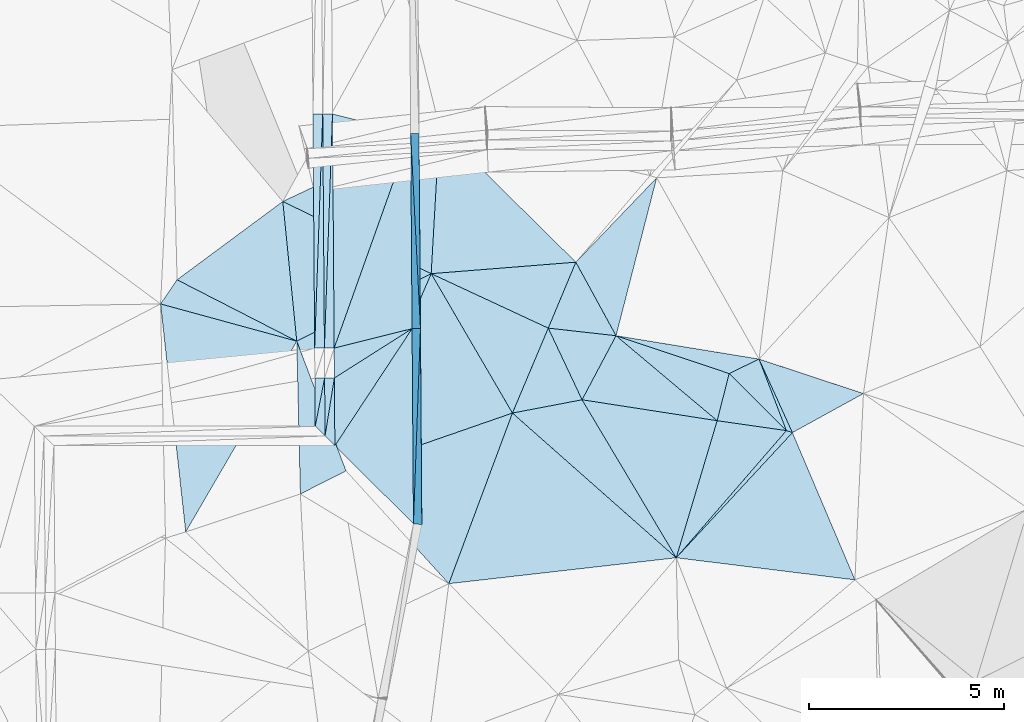
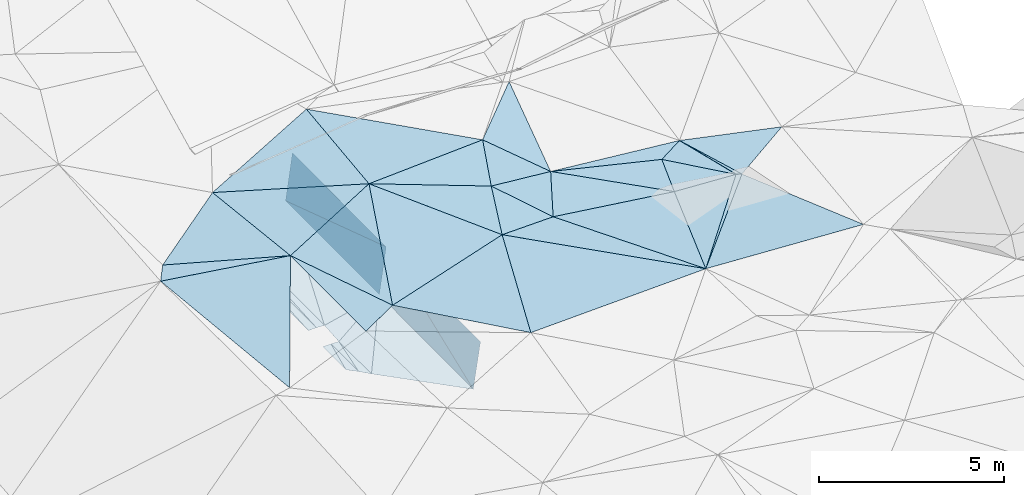
# One storey, part 99 of 275: 46 plates.
"""IFC2X3 building model written with IfcOpenShell, lengths in millimetres."""

from ifc_helpers import new_model, si_unit, frame, origin_with_axes, place, context, subcontext, project, spatial, polyline, outline, extrude, material, type_object, element, save


model = new_model("IFC2X3")

# Units and contexts
model_context = context("Model", 3, precision=1e-05, world=origin_with_axes())
body_context = subcontext(model_context, "Body", "Model", "MODEL_VIEW")
ifc_project = project(units=[si_unit("LENGTHUNIT", "METRE", prefix="MILLI"), si_unit("AREAUNIT", "SQUARE_METRE"), si_unit("VOLUMEUNIT", "CUBIC_METRE"), si_unit("MASSUNIT", "GRAM", prefix="KILO"), si_unit("TIMEUNIT", "SECOND"), si_unit("PLANEANGLEUNIT", "RADIAN"), si_unit("SOLIDANGLEUNIT", "STERADIAN"), si_unit("THERMODYNAMICTEMPERATUREUNIT", "DEGREE_CELSIUS"), si_unit("LUMINOUSINTENSITYUNIT", "LUMEN")], contexts=[model_context])

# Site, building, storey
site_placement = place(None, origin_with_axes())
site = spatial("IfcSite", under=ifc_project, at=site_placement, CompositionType="ELEMENT")
building_placement = place(site_placement, origin_with_axes())
building = spatial("IfcBuilding", under=site, at=building_placement, Name="Undefined", CompositionType="ELEMENT")
storey_placement = place(building_placement, origin_with_axes())
storey = spatial("IfcBuildingStorey", under=building, at=storey_placement, Name="Undefined", CompositionType="ELEMENT", Elevation=0.0)

# Plates
ifc_material = material()
plate_type_1 = type_object("IfcPlateType", PredefinedType="NOTDEFINED")
plate_1_placement = place(storey_placement, frame((-38804.1459852921, 42094.3332256138, 44429.500769745), z_axis=(0.0555257662861849, -0.00520451636578877, -0.998443690093603), x_axis=(0.285934340312549, 0.958187139763384, 0.0109067970593126)))
element("IfcPlate", 1, at=plate_1_placement, inside=storey, type_object=plate_type_1, material=ifc_material, Name="00", context=body_context, shape_type="SweptSolid", body=[
    extrude(outline(polyline([(0.0, 0.0), (3667.43774414063, 6.25732354819775e-10), (3932.2275390625, 1775.60876464844), (0.0, 0.0)])), frame((-8.85201319254618e-08, 2.18876761149539e-07, -0.5000001331573), z_axis=(0.0, 0.0, 1.0), x_axis=(1.0, 0.0, 0.0)), (0.0, 0.0, 1.0), 1.0),
])
plate_type_2 = type_object("IfcPlateType", PredefinedType="NOTDEFINED")
plate_2_placement = place(storey_placement, frame((-45538.5353842683, 42966.5050686624, 42291.0672885135), z_axis=(0.989902123787264, 0.00969248923613964, -0.141420793993923), x_axis=(-0.00717845203227998, 0.999807203879401, 0.0182763480289049)))
element("IfcPlate", 2, at=plate_2_placement, inside=storey, type_object=plate_type_2, material=ifc_material, Name="00_PR", context=body_context, shape_type="SweptSolid", body=[
    extrude(outline(polyline([(0.0, 0.0), (5000.8349609375, 5.12955011799932e-09), (5028.2490234375, 1514.98083496094), (0.0, 0.0)])), frame((-8.85201319254618e-08, 2.18876761149539e-07, -0.5000001331573), z_axis=(0.0, 0.0, 1.0), x_axis=(1.0, 0.0, 0.0)), (0.0, 0.0, 1.0), 1.0),
])
plate_type_3 = type_object("IfcPlateType", PredefinedType="NOTDEFINED")
for number, where, z_axis, x_axis, name in (
    (3, (-45396.0518271226, 52967.7848964947, 43960.1482889428), (0.989905826541836, 0.00930464635209911, -0.14142092537806), (0.00717878401248053, -0.999853554844082, -0.0155349259976933), "00_PR"),
    (4, (-45574.4336350125, 47966.375828221, 42382.4642885271), (0.989905826541836, 0.00930464635209911, -0.14142092537806), (-0.00717878403133616, 0.99985355484347, 0.0155349260283608), "00_PR"),
):
    element("IfcPlate", number, at=place(storey_placement, frame(where, z_axis=z_axis, x_axis=x_axis)), inside=storey, type_object=plate_type_3, material=ifc_material, Name=name, context=body_context, shape_type="SweptSolid", body=[
        extrude(outline(polyline([(0.0, 0.0), (5000.60302734375, -2.69210431724787e-09), (23.3020057678223, 1515.04956054688), (0.0, 0.0)])), frame((-8.85201319254618e-08, 2.18876761149539e-07, -0.5000001331573), z_axis=(0.0, 0.0, 1.0), x_axis=(1.0, 0.0, 0.0)), (0.0, 0.0, 1.0), 1.0),
    ])
plate_type_4 = type_object("IfcPlateType", PredefinedType="NOTDEFINED")
plate_3_placement = place(storey_placement, frame((-45360.1535715881, 47967.9141256778, 43882.4643262462), z_axis=(0.989912967878838, 0.00966846638336566, -0.141346513162173), x_axis=(0.00717851601274934, -0.999810135650778, -0.0181152299965372)))
element("IfcPlate", 5, at=plate_3_placement, inside=storey, type_object=plate_type_4, material=ifc_material, Name="00_PR", context=body_context, shape_type="SweptSolid", body=[
    extrude(outline(polyline([(0.0, 0.0), (5023.06640625, -4.80213202536106e-10), (5028.00732421875, 1515.78295898438), (0.0, 0.0)])), frame((-8.85201319254618e-08, 2.18876761149539e-07, -0.5000001331573), z_axis=(0.0, 0.0, 1.0), x_axis=(1.0, 0.0, 0.0)), (0.0, 0.0, 1.0), 1.0),
])
plate_type_5 = type_object("IfcPlateType", PredefinedType="NOTDEFINED")
plate_4_placement = place(storey_placement, frame((-47565.9271487293, 46702.5462935812, 42306.0864398168), z_axis=(-0.0410631592703812, 0.00859631674189456, -0.999119572568373), x_axis=(0.00717971499776486, -0.999934632850585, -0.00889841101079463)))
element("IfcPlate", 6, at=plate_4_placement, inside=storey, type_object=plate_type_5, material=ifc_material, Name="00_PR", context=body_context, shape_type="SweptSolid", body=[
    extrude(outline(polyline([(0.0, 0.0), (1736.04040527344, 1.23691279441118e-10), (1484.12268066406, 250.210830688477), (0.0, 0.0)])), frame((-8.85201319254618e-08, 2.18876761149539e-07, -0.5000001331573), z_axis=(0.0, 0.0, 1.0), x_axis=(1.0, 0.0, 0.0)), (0.0, 0.0, 1.0), 1.0),
])
plate_5_placement = place(storey_placement, frame((-47805.269380462, 45216.6350836019, 42303.1386502098), z_axis=(-0.0500084503955125, 0.0100363103769387, -0.998698366556718), x_axis=(-0.00717873499832695, 0.999920065903385, 0.0104080530164874)))
element("IfcPlate", 7, at=plate_5_placement, inside=storey, type_object=plate_type_5, material=ifc_material, Name="00_PR", context=body_context, shape_type="SweptSolid", body=[
    extrude(outline(polyline([(0.0, 0.0), (1484.2353515625, -4.35102265328169e-09), (1484.10571289063, 250.311416625977), (0.0, 0.0)])), frame((-8.85201319254618e-08, 2.18876761149539e-07, -0.5000001331573), z_axis=(0.0, 0.0, 1.0), x_axis=(1.0, 0.0, 0.0)), (0.0, 0.0, 1.0), 1.0),
])
plate_6_placement = place(storey_placement, frame((-47864.4791608798, 53468.2404815311, 42480.5971601308), z_axis=(0.0198811598934889, 0.0157251391534212, -0.999678678116071), x_axis=(0.00717889702380228, -0.99985277310037, -0.0155851070262992)))
element("IfcPlate", 8, at=plate_6_placement, inside=storey, type_object=plate_type_5, material=ifc_material, Name="00_PR", context=body_context, shape_type="SweptSolid", body=[
    extrude(outline(polyline([(0.0, 0.0), (6000.728515625, -3.76894604414701e-09), (6000.806640625, 250.050430297852), (0.0, 0.0)])), frame((-8.85201319254618e-08, 2.18876761149539e-07, -0.5000001331573), z_axis=(0.0, 0.0, 1.0), x_axis=(1.0, 0.0, 0.0)), (0.0, 0.0, 1.0), 1.0),
])
plate_7_placement = place(storey_placement, frame((-47614.5205176006, 53470.035871113, 42468.0976839344), z_axis=(-0.050042229030528, 0.0152067736040165, -0.998631328043644), x_axis=(0.00717889702380228, -0.99985277310037, -0.0155851070262992)))
element("IfcPlate", 9, at=plate_7_placement, inside=storey, type_object=plate_type_5, material=ifc_material, Name="00_PR", context=body_context, shape_type="SweptSolid", body=[
    extrude(outline(polyline([(0.0, 0.0), (6000.72900390625, 1.8364517018199e-08), (6000.53466796875, 250.311370849609), (0.0, 0.0)])), frame((-8.85201319254618e-08, 2.18876761149539e-07, -0.5000001331573), z_axis=(0.0, 0.0, 1.0), x_axis=(1.0, 0.0, 0.0)), (0.0, 0.0, 1.0), 1.0),
])
plate_8_placement = place(storey_placement, frame((-47815.8841157634, 46700.752060617, 42318.5862587669), z_axis=(0.0303930181563116, 0.0106216898156484, -0.999481587700749), x_axis=(0.00717873501905341, -0.999920065903206, -0.0104080530193897)))
element("IfcPlate", 10, at=plate_8_placement, inside=storey, type_object=plate_type_5, material=ifc_material, Name="00_PR", context=body_context, shape_type="SweptSolid", body=[
    extrude(outline(polyline([(0.0, 0.0), (1484.2353515625, -4.35102265328169e-09), (1232.4853515625, 250.115463256836), (0.0, 0.0)])), frame((-8.85201319254618e-08, 2.18876761149539e-07, -0.5000001331573), z_axis=(0.0, 0.0, 1.0), x_axis=(1.0, 0.0, 0.0)), (0.0, 0.0, 1.0), 1.0),
])
plate_9_placement = place(storey_placement, frame((-47821.4355090784, 47468.3949556743, 42387.075683854), z_axis=(-0.050042229030528, 0.0152067736040165, -0.998631328043644), x_axis=(-0.00717889701761236, 0.999852773100498, 0.0155851070209677)))
element("IfcPlate", 11, at=plate_9_placement, inside=storey, type_object=plate_type_5, material=ifc_material, Name="00_PR", context=body_context, shape_type="SweptSolid", body=[
    extrude(outline(polyline([(0.0, 0.0), (6000.728515625, -3.76894604414701e-09), (6000.53466796875, 250.312286376953), (0.0, 0.0)])), frame((-8.85201319254618e-08, 2.18876761149539e-07, -0.5000001331573), z_axis=(0.0, 0.0, 1.0), x_axis=(1.0, 0.0, 0.0)), (0.0, 0.0, 1.0), 1.0),
])
plate_10_placement = place(storey_placement, frame((-48057.0351421219, 45466.6508383166, 42298.1381389556), z_axis=(0.0199039131804449, 0.012675255587071, -0.999721547300001), x_axis=(-0.00717946102947982, 0.999895665080592, 0.0125345240183438)))
element("IfcPlate", 12, at=plate_10_placement, inside=storey, type_object=plate_type_5, material=ifc_material, Name="00_PR", context=body_context, shape_type="SweptSolid", body=[
    extrude(outline(polyline([(0.0, 0.0), (1232.43615722656, -4.04543243348598e-09), (1232.49853515625, 250.050445556641), (0.0, 0.0)])), frame((-8.85201319254618e-08, 2.18876761149539e-07, -0.5000001331573), z_axis=(0.0, 0.0, 1.0), x_axis=(1.0, 0.0, 0.0)), (0.0, 0.0, 1.0), 1.0),
])
plate_11_placement = place(storey_placement, frame((-48071.3945519694, 47466.6004835833, 42382.0751615357), z_axis=(0.0198811598934889, 0.0157251391534212, -0.999678678116071), x_axis=(-0.00717889701761236, 0.999852773100498, 0.0155851070209677)))
element("IfcPlate", 13, at=plate_11_placement, inside=storey, type_object=plate_type_5, material=ifc_material, Name="00_PR", context=body_context, shape_type="SweptSolid", body=[
    extrude(outline(polyline([(0.0, 0.0), (6000.72900390625, 1.8364517018199e-08), (6000.806640625, 250.049514770508), (0.0, 0.0)])), frame((-8.85201319254618e-08, 2.18876761149539e-07, -0.5000001331573), z_axis=(0.0, 0.0, 1.0), x_axis=(1.0, 0.0, 0.0)), (0.0, 0.0, 1.0), 1.0),
])
plate_type_6 = type_object("IfcPlateType", PredefinedType="NOTDEFINED")
plate_12_placement = place(storey_placement, frame((-47614.4956241816, 53470.0360616883, 42468.0970604378), z_axis=(-0.00026260331269606, 0.0155836220431683, -0.999878533504703), x_axis=(0.969806907107943, -0.243840356027268, -0.00405508301040401)))
element("IfcPlate", 14, at=plate_12_placement, inside=storey, type_object=plate_type_6, material=ifc_material, Name="00_PR", context=body_context, shape_type="SweptSolid", body=[
    extrude(outline(polyline([(0.0, 0.0), (2066.04907226563, -2.7648638933897e-09), (1505.16076660156, 5808.89306640625), (0.0, 0.0)])), frame((-8.85201319254618e-08, 2.18876761149539e-07, -0.5000001331573), z_axis=(0.0, 0.0, 1.0), x_axis=(1.0, 0.0, 0.0)), (0.0, 0.0, 1.0), 1.0),
])
plate_13_placement = place(storey_placement, frame((-45574.919450901, 47966.3803782759, 42382.0351673009), z_axis=(0.0182743013456263, 0.0184049294161911, -0.999663597658489), x_axis=(0.00717845203193807, -0.999807203879423, -0.0182763480278442)))
element("IfcPlate", 15, at=plate_13_placement, inside=storey, type_object=plate_type_6, material=ifc_material, Name="00_PR", context=body_context, shape_type="SweptSolid", body=[
    extrude(outline(polyline([(0.0, 0.0), (5000.8349609375, 5.12955011799932e-09), (2986.6455078125, 2000.3388671875), (0.0, 0.0)])), frame((-8.85201319254618e-08, 2.18876761149539e-07, -0.5000001331573), z_axis=(0.0, 0.0, 1.0), x_axis=(1.0, 0.0, 0.0)), (0.0, 0.0, 1.0), 1.0),
])
plate_type_7 = type_object("IfcPlateType", PredefinedType="NOTDEFINED")
plate_14_placement = place(storey_placement, frame((-45574.937748193, 47966.4155373321, 42382.0370556278), z_axis=(-0.0183288493569482, 0.0887216577594548, -0.995887805290167), x_axis=(-0.843829772918599, -0.535644628944066, -0.0321892189951985)))
element("IfcPlate", 16, at=plate_14_placement, inside=storey, type_object=plate_type_7, material=ifc_material, Name="00_PR", context=body_context, shape_type="SweptSolid", body=[
    extrude(outline(polyline([(0.0, 0.0), (2359.45458984375, -2.895831130445e-09), (1950.71789550781, 653.396911621094), (0.0, 0.0)])), frame((-8.85201319254618e-08, 2.18876761149539e-07, -0.5000001331573), z_axis=(0.0, 0.0, 1.0), x_axis=(1.0, 0.0, 0.0)), (0.0, 0.0, 1.0), 1.0),
])
plate_type_8 = type_object("IfcPlateType", PredefinedType="NOTDEFINED")
plate_15_placement = place(storey_placement, frame((-45574.9124177367, 47966.3757393054, 42382.0352817664), z_axis=(0.0323319858735923, 0.00912611893456167, -0.999435519001933), x_axis=(-0.550407293123912, -0.834509037188206, -0.0254259420124746)))
element("IfcPlate", 17, at=plate_15_placement, inside=storey, type_object=plate_type_8, material=ifc_material, Name="00_PR", context=body_context, shape_type="SweptSolid", body=[
    extrude(outline(polyline([(0.0, 0.0), (3594.6357421875, -1.86264514923096e-09), (2152.45678710938, 966.413879394531), (0.0, 0.0)])), frame((-8.85201319254618e-08, 2.18876761149539e-07, -0.5000001331573), z_axis=(0.0, 0.0, 1.0), x_axis=(1.0, 0.0, 0.0)), (0.0, 0.0, 1.0), 1.0),
])
plate_type_9 = type_object("IfcPlateType", PredefinedType="NOTDEFINED")
plate_16_placement = place(storey_placement, frame((-45610.8269022781, 52966.2498957004, 42459.7190597298), z_axis=(-0.000124672575715643, 0.0155344312998982, -0.999879325669322), x_axis=(0.00717878401248053, -0.999853554844082, -0.0155349259976933)))
element("IfcPlate", 18, at=plate_16_placement, inside=storey, type_object=plate_type_9, material=ifc_material, Name="00_PR", context=body_context, shape_type="SweptSolid", body=[
    extrude(outline(polyline([(0.0, 0.0), (5000.60302734375, -2.69210431724787e-09), (5482.5029296875, 2000.00024414063), (0.0, 0.0)])), frame((-8.85201319254618e-08, 2.18876761149539e-07, -0.5000001331573), z_axis=(0.0, 0.0, 1.0), x_axis=(1.0, 0.0, 0.0)), (0.0, 0.0, 1.0), 1.0),
])
plate_type_10 = type_object("IfcPlateType", PredefinedType="NOTDEFINED")
plate_17_placement = place(storey_placement, frame((-48529.4223785102, 47646.0798375539, 44899.5009445724), z_axis=(0.0495627242901146, 0.0368314662946448, -0.998091668861898), x_axis=(0.354834335572794, -0.934776889817633, -0.0168748499693179)))
element("IfcPlate", 19, at=plate_17_placement, inside=storey, type_object=plate_type_10, material=ifc_material, Name="00", context=body_context, shape_type="SweptSolid", body=[
    extrude(outline(polyline([(0.0, 0.0), (3555.58715820313, 7.60701368562877e-09), (3696.82958984375, 1306.69445800781), (0.0, 0.0)])), frame((-8.85201319254618e-08, 2.18876761149539e-07, -0.5000001331573), z_axis=(0.0, 0.0, 1.0), x_axis=(1.0, 0.0, 0.0)), (0.0, 0.0, 1.0), 1.0),
])
plate_type_11 = type_object("IfcPlateType", PredefinedType="NOTDEFINED")
plate_18_placement = place(storey_placement, frame((-47267.7931569972, 44322.3933867049, 44839.5002430228), z_axis=(0.0191941221617469, 0.0253291026365271, -0.999494883545718), x_axis=(-0.354834335571538, 0.934776889818193, 0.0168748499646969)))
element("IfcPlate", 20, at=plate_18_placement, inside=storey, type_object=plate_type_11, material=ifc_material, Name="00", context=body_context, shape_type="SweptSolid", body=[
    extrude(outline(polyline([(0.0, 0.0), (3555.58715820313, 7.60701368562877e-09), (3952.87744140625, 3835.73461914063), (0.0, 0.0)])), frame((-8.85201319254618e-08, 2.18876761149539e-07, -0.5000001331573), z_axis=(0.0, 0.0, 1.0), x_axis=(1.0, 0.0, 0.0)), (0.0, 0.0, 1.0), 1.0),
])
plate_type_12 = type_object("IfcPlateType", PredefinedType="NOTDEFINED")
plate_19_placement = place(storey_placement, frame((-35981.2174434766, 45354.1912212937, 44569.5018309828), z_axis=(-0.0388013774533662, 0.0763909461579143, -0.996322676873723), x_axis=(0.945648817482598, -0.319357034532821, -0.0613139338826493)))
element("IfcPlate", 21, at=plate_19_placement, inside=storey, type_object=plate_type_12, material=ifc_material, Name="00", context=body_context, shape_type="SweptSolid", body=[
    extrude(outline(polyline([(0.0, 0.0), (163.095062255859, -3.45607986673713e-10), (-1619.91418457031, 3998.88452148438), (0.0, 0.0)])), frame((-8.85201319254618e-08, 2.18876761149539e-07, -0.5000001331573), z_axis=(0.0, 0.0, 1.0), x_axis=(1.0, 0.0, 0.0)), (0.0, 0.0, 1.0), 1.0),
])
plate_type_13 = type_object("IfcPlateType", PredefinedType="NOTDEFINED")
plate_20_placement = place(storey_placement, frame((-36682.261469094, 47187.2809516317, 44819.504161099), z_axis=(-0.0213850289381097, 0.127068002488683, -0.991663452629395), x_axis=(0.409940372558758, -0.903559081764431, -0.124618925959922)))
element("IfcPlate", 22, at=plate_20_placement, inside=storey, type_object=plate_type_13, material=ifc_material, Name="00", context=body_context, shape_type="SweptSolid", body=[
    extrude(outline(polyline([(0.0, 0.0), (2086.3603515625, 5.87897375226021e-09), (1974.82653808594, 118.996559143066), (0.0, 0.0)])), frame((-8.85201319254618e-08, 2.18876761149539e-07, -0.5000001331573), z_axis=(0.0, 0.0, 1.0), x_axis=(1.0, 0.0, 0.0)), (0.0, 0.0, 1.0), 1.0),
])
plate_type_14 = type_object("IfcPlateType", PredefinedType="NOTDEFINED")
plate_21_placement = place(storey_placement, frame((-41217.8244882846, 46144.2771883733, 44529.503115221), z_axis=(0.00674103570133747, 0.111407040917179, -0.993751996059254), x_axis=(-0.424686527755329, 0.900018789191495, 0.0980180200034566)))
element("IfcPlate", 23, at=plate_21_placement, inside=storey, type_object=plate_type_14, material=ifc_material, Name="00", context=body_context, shape_type="SweptSolid", body=[
    extrude(outline(polyline([(0.0, 0.0), (2040.44116210938, -4.66388883069158e-09), (1126.96215820313, 1490.01892089844), (0.0, 0.0)])), frame((-8.85201319254618e-08, 2.18876761149539e-07, -0.5000001331573), z_axis=(0.0, 0.0, 1.0), x_axis=(1.0, 0.0, 0.0)), (0.0, 0.0, 1.0), 1.0),
])
plate_type_15 = type_object("IfcPlateType", PredefinedType="NOTDEFINED")
plate_22_placement = place(storey_placement, frame((-48887.9290468764, 51226.8882426171, 44929.5001954332), z_axis=(0.0263880104203228, 0.0110163843894979, -0.999591072479662), x_axis=(0.89905005933514, -0.437437187511466, 0.0189129001355952)))
element("IfcPlate", 24, at=plate_22_placement, inside=storey, type_object=plate_type_15, material=ifc_material, Name="00", context=body_context, shape_type="SweptSolid", body=[
    extrude(outline(polyline([(0.0, 0.0), (4229.91748046875, 1.3445969671011e-08), (1888.1220703125, 3063.771484375), (0.0, 0.0)])), frame((-8.85201319254618e-08, 2.18876761149539e-07, -0.5000001331573), z_axis=(0.0, 0.0, 1.0), x_axis=(1.0, 0.0, 0.0)), (0.0, 0.0, 1.0), 1.0),
])
plate_type_16 = type_object("IfcPlateType", PredefinedType="NOTDEFINED")
plate_23_placement = place(storey_placement, frame((-37755.5270772457, 45608.4848912251, 44469.5032896682), z_axis=(0.000528433898829724, 0.114659527082405, -0.993404707864249), x_axis=(-0.988092058966253, 0.152908078396037, 0.0171231588517608)))
element("IfcPlate", 25, at=plate_23_placement, inside=storey, type_object=plate_type_16, material=ifc_material, Name="00", context=body_context, shape_type="SweptSolid", body=[
    extrude(outline(polyline([(0.0, 0.0), (3504.0263671875, -6.17728801444173e-09), (2898.40869140625, 1767.32202148438), (0.0, 0.0)])), frame((-8.85201319254618e-08, 2.18876761149539e-07, -0.5000001331573), z_axis=(0.0, 0.0, 1.0), x_axis=(1.0, 0.0, 0.0)), (0.0, 0.0, 1.0), 1.0),
])
plate_type_17 = type_object("IfcPlateType", PredefinedType="NOTDEFINED")
plate_24_placement = place(storey_placement, frame((-36682.2199578828, 47187.3245981348, 44819.5125883462), z_axis=(0.061636587315607, 0.214359893094708, -0.974808066922156), x_axis=(-0.889446371471232, -0.43134275140688, -0.151091307113951)))
element("IfcPlate", 26, at=plate_24_placement, inside=storey, type_object=plate_type_17, material=ifc_material, Name="00", context=body_context, shape_type="SweptSolid", body=[
    extrude(outline(polyline([(0.0, 0.0), (860.406860351563, 9.53150447458029e-10), (3016.71215820313, 2168.5126953125), (0.0, 0.0)])), frame((-8.85201319254618e-08, 2.18876761149539e-07, -0.5000001331573), z_axis=(0.0, 0.0, 1.0), x_axis=(1.0, 0.0, 0.0)), (0.0, 0.0, 1.0), 1.0),
])
plate_type_18 = type_object("IfcPlateType", PredefinedType="NOTDEFINED")
plate_25_placement = place(storey_placement, frame((-42084.3858479769, 47980.7341282394, 44729.5061052114), z_axis=(-0.0202617314086041, 0.154579370958513, -0.987772585322348), x_axis=(-0.903464711090975, 0.42029062338382, 0.0843048498542142)))
element("IfcPlate", 27, at=plate_25_placement, inside=storey, type_object=plate_type_18, material=ifc_material, Name="00", context=body_context, shape_type="SweptSolid", body=[
    extrude(outline(polyline([(0.0, 0.0), (3321.27978515625, -3.88899934478104e-09), (92.7353363037109, 1846.72692871094), (0.0, 0.0)])), frame((-8.85201319254618e-08, 2.18876761149539e-07, -0.5000001331573), z_axis=(0.0, 0.0, 1.0), x_axis=(1.0, 0.0, 0.0)), (0.0, 0.0, 1.0), 1.0),
])
plate_type_19 = type_object("IfcPlateType", PredefinedType="NOTDEFINED")
plate_26_placement = place(storey_placement, frame((-45085.0513751244, 49376.583540017, 45009.5008356498), z_axis=(-0.0329915490159639, 0.047826899089553, -0.998310645749611), x_axis=(0.502718449236739, -0.86250667920047, -0.0579343519130575)))
element("IfcPlate", 28, at=plate_26_placement, inside=storey, type_object=plate_type_19, material=ifc_material, Name="00", context=body_context, shape_type="SweptSolid", body=[
    extrude(outline(polyline([(0.0, 0.0), (4142.6201171875, -1.38297764351591e-08), (3271.79418945313, 4430.96630859375), (0.0, 0.0)])), frame((-8.85201319254618e-08, 2.18876761149539e-07, -0.5000001331573), z_axis=(0.0, 0.0, 1.0), x_axis=(1.0, 0.0, 0.0)), (0.0, 0.0, 1.0), 1.0),
])
plate_type_20 = type_object("IfcPlateType", PredefinedType="NOTDEFINED")
plate_27_placement = place(storey_placement, frame((-45085.0177121166, 49376.5733146565, 45009.5004741506), z_axis=(0.0343371435728062, 0.0273780044993256, -0.99903523733695), x_axis=(-0.899050059338203, 0.437437187505031, -0.0189129001388547)))
element("IfcPlate", 29, at=plate_27_placement, inside=storey, type_object=plate_type_20, material=ifc_material, Name="00", context=body_context, shape_type="SweptSolid", body=[
    extrude(outline(polyline([(0.0, 0.0), (4229.91748046875, 1.3445969671011e-08), (1444.73278808594, 3464.7578125), (0.0, 0.0)])), frame((-8.85201319254618e-08, 2.18876761149539e-07, -0.5000001331573), z_axis=(0.0, 0.0, 1.0), x_axis=(1.0, 0.0, 0.0)), (0.0, 0.0, 1.0), 1.0),
])
plate_type_21 = type_object("IfcPlateType", PredefinedType="NOTDEFINED")
plate_28_placement = place(storey_placement, frame((-40347.4735842983, 47786.445210844, 44719.5076068308), z_axis=(0.0459172370208679, 0.167685860938483, -0.984770561798884), x_axis=(0.948281842618637, -0.317277972577557, -0.00980994785296144)))
element("IfcPlate", 30, at=plate_28_placement, inside=storey, type_object=plate_type_21, material=ifc_material, Name="00", context=body_context, shape_type="SweptSolid", body=[
    extrude(outline(polyline([(0.0, 0.0), (3058.12036132813, -6.98491930961609e-09), (3151.38012695313, 1262.14208984375), (0.0, 0.0)])), frame((-8.85201319254618e-08, 2.18876761149539e-07, -0.5000001331573), z_axis=(0.0, 0.0, 1.0), x_axis=(1.0, 0.0, 0.0)), (0.0, 0.0, 1.0), 1.0),
])
plate_type_22 = type_object("IfcPlateType", PredefinedType="NOTDEFINED")
plate_29_placement = place(storey_placement, frame((-35981.1550691648, 45354.2364412905, 44569.5088759879), z_axis=(0.0859472884538605, 0.166830847829681, -0.982232422504907), x_axis=(-0.706983263711571, 0.704859722866362, 0.057857029931462)))
element("IfcPlate", 31, at=plate_29_placement, inside=storey, type_object=plate_type_22, material=ifc_material, Name="00", context=body_context, shape_type="SweptSolid", body=[
    extrude(outline(polyline([(0.0, 0.0), (2074.078125, -7.22138793207705e-09), (1802.15002441406, 816.305786132813), (0.0, 0.0)])), frame((-8.85201319254618e-08, 2.18876761149539e-07, -0.5000001331573), z_axis=(0.0, 0.0, 1.0), x_axis=(1.0, 0.0, 0.0)), (0.0, 0.0, 1.0), 1.0),
])
plate_type_23 = type_object("IfcPlateType", PredefinedType="NOTDEFINED")
plate_30_placement = place(storey_placement, frame((-41377.4160266758, 49670.909910062, 44979.5050951146), z_axis=(0.0102013732149394, 0.142136594607273, -0.989794483950066), x_axis=(0.476103154368963, -0.871137249402288, -0.120190178898857)))
element("IfcPlate", 32, at=plate_30_placement, inside=storey, type_object=plate_type_23, material=ifc_material, Name="00", context=body_context, shape_type="SweptSolid", body=[
    extrude(outline(polyline([(0.0, 0.0), (2163.23828125, 1.07138475868851e-09), (1165.8447265625, 1435.20239257813), (0.0, 0.0)])), frame((-8.85201319254618e-08, 2.18876761149539e-07, -0.5000001331573), z_axis=(0.0, 0.0, 1.0), x_axis=(1.0, 0.0, 0.0)), (0.0, 0.0, 1.0), 1.0),
])
plate_type_24 = type_object("IfcPlateType", PredefinedType="NOTDEFINED")
plate_31_placement = place(storey_placement, frame((-48529.4218177173, 47646.0505575421, 44899.5007508561), z_axis=(0.0506844617877374, -0.0217279887844734, -0.99847833218186), x_axis=(-0.963131923054588, 0.263426012404755, -0.0546226581347042)))
element("IfcPlate", 33, at=plate_31_placement, inside=storey, type_object=plate_type_24, material=ifc_material, Name="00", context=body_context, shape_type="SweptSolid", body=[
    extrude(outline(polyline([(0.0, 0.0), (3624.86938476563, 1.23109202831984e-08), (3380.15209960938, 708.499450683594), (0.0, 0.0)])), frame((-8.85201319254618e-08, 2.18876761149539e-07, -0.5000001331573), z_axis=(0.0, 0.0, 1.0), x_axis=(1.0, 0.0, 0.0)), (0.0, 0.0, 1.0), 1.0),
])
plate_type_25 = type_object("IfcPlateType", PredefinedType="NOTDEFINED")
plate_32_placement = place(storey_placement, frame((-37447.4974069924, 46816.1668017414, 44689.5079328369), z_axis=(0.0782945800797509, 0.159309943981933, -0.984119047919818), x_axis=(0.706983263715458, -0.704859722862735, -0.0578570299281601)))
element("IfcPlate", 34, at=plate_32_placement, inside=storey, type_object=plate_type_25, material=ifc_material, Name="00", context=body_context, shape_type="SweptSolid", body=[
    extrude(outline(polyline([(0.0, 0.0), (2074.078125, -7.22138793207705e-09), (646.21484375, 1088.16650390625), (0.0, 0.0)])), frame((-8.85201319254618e-08, 2.18876761149539e-07, -0.5000001331573), z_axis=(0.0, 0.0, 1.0), x_axis=(1.0, 0.0, 0.0)), (0.0, 0.0, 1.0), 1.0),
])
plate_type_26 = type_object("IfcPlateType", PredefinedType="NOTDEFINED")
plate_33_placement = place(storey_placement, frame((-35826.9302659909, 45302.1520844411, 44559.5086037882), z_axis=(0.0742439391378555, 0.169228700814515, -0.982776416242233), x_axis=(-0.409940372555941, 0.90355908176635, 0.124618925955276)))
element("IfcPlate", 35, at=plate_33_placement, inside=storey, type_object=plate_type_26, material=ifc_material, Name="00", context=body_context, shape_type="SweptSolid", body=[
    extrude(outline(polyline([(0.0, 0.0), (2086.3603515625, 5.87897375226021e-09), (197.377212524414, 2091.51684570313), (0.0, 0.0)])), frame((-8.85201319254618e-08, 2.18876761149539e-07, -0.5000001331573), z_axis=(0.0, 0.0, 1.0), x_axis=(1.0, 0.0, 0.0)), (0.0, 0.0, 1.0), 1.0),
])
plate_type_27 = type_object("IfcPlateType", PredefinedType="NOTDEFINED")
plate_34_placement = place(storey_placement, frame((-48529.4123468929, 47646.0690854899, 44899.5012627804), z_axis=(0.0696264330724566, 0.0153273203867326, -0.997455378985631), x_axis=(-0.888444615283114, 0.455674797478738, -0.0550149481245803)))
element("IfcPlate", 36, at=plate_34_placement, inside=storey, type_object=plate_type_27, material=ifc_material, Name="00", context=body_context, shape_type="SweptSolid", body=[
    extrude(outline(polyline([(0.0, 0.0), (3453.60668945313, -1.16015144158155e-08), (1948.54260253906, 3025.70361328125), (0.0, 0.0)])), frame((-8.85201319254618e-08, 2.18876761149539e-07, -0.5000001331573), z_axis=(0.0, 0.0, 1.0), x_axis=(1.0, 0.0, 0.0)), (0.0, 0.0, 1.0), 1.0),
])
plate_type_28 = type_object("IfcPlateType", PredefinedType="NOTDEFINED")
plate_35_placement = place(storey_placement, frame((-44871.5694807095, 53122.790059482, 45119.5002436522), z_axis=(-0.0104641260338242, 0.0299444683792882, -0.999496788829174), x_axis=(0.711101478809003, -0.702511855959214, -0.0284917369142334)))
element("IfcPlate", 37, at=plate_35_placement, inside=storey, type_object=plate_type_28, material=ifc_material, Name="00", context=body_context, shape_type="SweptSolid", body=[
    extrude(outline(polyline([(0.0, 0.0), (4913.70556640625, -6.69660948915407e-09), (2483.095703125, 2815.32177734375), (0.0, 0.0)])), frame((-8.85201319254618e-08, 2.18876761149539e-07, -0.5000001331573), z_axis=(0.0, 0.0, 1.0), x_axis=(1.0, 0.0, 0.0)), (0.0, 0.0, 1.0), 1.0),
])
plate_type_29 = type_object("IfcPlateType", PredefinedType="NOTDEFINED")
plate_36_placement = place(storey_placement, frame((-45085.0772979206, 49376.5683614059, 45009.5018705012), z_axis=(-0.084834792335636, 0.0174707175670994, -0.99624185418856), x_axis=(0.903464711091764, -0.420290623384249, -0.0843048498436154)))
element("IfcPlate", 38, at=plate_36_placement, inside=storey, type_object=plate_type_29, material=ifc_material, Name="00", context=body_context, shape_type="SweptSolid", body=[
    extrude(outline(polyline([(0.0, 0.0), (3321.27978515625, -3.88899934478104e-09), (3403.47705078125, 2361.70361328125), (0.0, 0.0)])), frame((-8.85201319254618e-08, 2.18876761149539e-07, -0.5000001331573), z_axis=(0.0, 0.0, 1.0), x_axis=(1.0, 0.0, 0.0)), (0.0, 0.0, 1.0), 1.0),
])
plate_type_30 = type_object("IfcPlateType", PredefinedType="NOTDEFINED")
plate_37_placement = place(storey_placement, frame((-42084.4461662032, 47980.6774596715, 44729.5054090705), z_axis=(-0.140897514667654, 0.0412421363744956, -0.989164787357367), x_axis=(0.424686527759255, -0.90001878918925, -0.0980180200070523)))
element("IfcPlate", 39, at=plate_37_placement, inside=storey, type_object=plate_type_30, material=ifc_material, Name="00", context=body_context, shape_type="SweptSolid", body=[
    extrude(outline(polyline([(0.0, 0.0), (2040.44116210938, -4.66388883069158e-09), (1565.64184570313, 1770.07507324219), (0.0, 0.0)])), frame((-8.85201319254618e-08, 2.18876761149539e-07, -0.5000001331573), z_axis=(0.0, 0.0, 1.0), x_axis=(1.0, 0.0, 0.0)), (0.0, 0.0, 1.0), 1.0),
])
plate_type_31 = type_object("IfcPlateType", PredefinedType="NOTDEFINED")
plate_38_placement = place(storey_placement, frame((-35826.9455751522, 45302.0674691974, 44559.5004681788), z_axis=(0.0436250534774195, -1.41785539991071e-06, -0.999047974176957), x_axis=(0.390860293663433, -0.920291739064646, 0.0170688560456041)))
element("IfcPlate", 40, at=plate_38_placement, inside=storey, type_object=plate_type_31, material=ifc_material, Name="00", context=body_context, shape_type="SweptSolid", body=[
    extrude(outline(polyline([(0.0, 0.0), (4101.03662109375, -5.41876943316311e-09), (1786.158203125, 3997.47900390625), (0.0, 0.0)])), frame((-8.85201319254618e-08, 2.18876761149539e-07, -0.5000001331573), z_axis=(0.0, 0.0, 1.0), x_axis=(1.0, 0.0, 0.0)), (0.0, 0.0, 1.0), 1.0),
])
plate_type_32 = type_object("IfcPlateType", PredefinedType="NOTDEFINED")
plate_39_placement = place(storey_placement, frame((-38804.2356780998, 42094.3111550085, 44429.5044558573), z_axis=(-0.123859984259899, -0.0493465697409328, -0.99107195518486), x_axis=(-0.748035050401655, 0.660888523543911, 0.0605798879046693)))
element("IfcPlate", 41, at=plate_39_placement, inside=storey, type_object=plate_type_32, material=ifc_material, Name="00", context=body_context, shape_type="SweptSolid", body=[
    extrude(outline(polyline([(0.0, 0.0), (5612.423828125, 2.62934918282554e-08), (4488.07861328125, 1447.22094726563), (0.0, 0.0)])), frame((-8.85201319254618e-08, 2.18876761149539e-07, -0.5000001331573), z_axis=(0.0, 0.0, 1.0), x_axis=(1.0, 0.0, 0.0)), (0.0, 0.0, 1.0), 1.0),
])
plate_type_33 = type_object("IfcPlateType", PredefinedType="NOTDEFINED")
plate_40_placement = place(storey_placement, frame((-43002.4937976024, 45803.5335918424, 44769.5010446196), z_axis=(-0.0607837390233732, 0.0226723636631696, -0.997893431683095), x_axis=(0.748035050402028, -0.660888523543636, -0.0605798879030675)))
element("IfcPlate", 42, at=plate_40_placement, inside=storey, type_object=plate_type_33, material=ifc_material, Name="00", context=body_context, shape_type="SweptSolid", body=[
    extrude(outline(polyline([(0.0, 0.0), (5612.423828125, 2.62934918282554e-08), (1669.90246582031, 4358.2822265625), (0.0, 0.0)])), frame((-8.85201319254618e-08, 2.18876761149539e-07, -0.5000001331573), z_axis=(0.0, 0.0, 1.0), x_axis=(1.0, 0.0, 0.0)), (0.0, 0.0, 1.0), 1.0),
])
plate_type_34 = type_object("IfcPlateType", PredefinedType="NOTDEFINED")
plate_41_placement = place(storey_placement, frame((-44633.5845598634, 41430.5777353104, 44769.5000922084), z_axis=(-0.0188495095254013, 0.00703087617766873, -0.99979761090474), x_axis=(-0.673308244392715, 0.739145374533232, 0.0178919909157052)))
element("IfcPlate", 43, at=plate_41_placement, inside=storey, type_object=plate_type_34, material=ifc_material, Name="00", context=body_context, shape_type="SweptSolid", body=[
    extrude(outline(polyline([(0.0, 0.0), (3912.36499023438, -2.48564901994541e-09), (2134.00341796875, 4150.810546875), (0.0, 0.0)])), frame((-8.85201319254618e-08, 2.18876761149539e-07, -0.5000001331573), z_axis=(0.0, 0.0, 1.0), x_axis=(1.0, 0.0, 0.0)), (0.0, 0.0, 1.0), 1.0),
])
plate_type_35 = type_object("IfcPlateType", PredefinedType="NOTDEFINED")
plate_42_placement = place(storey_placement, frame((-51375.8934454462, 42757.6920860741, 44509.5015367866), z_axis=(0.0675355475935523, 0.0402085146587541, -0.996906327174312), x_axis=(-0.109616014617573, 0.993437861921898, 0.032642668999469)))
element("IfcPlate", 44, at=plate_42_placement, inside=storey, type_object=plate_type_35, material=ifc_material, Name="00", context=body_context, shape_type="SweptSolid", body=[
    extrude(outline(polyline([(0.0, 0.0), (5881.8720703125, -4.918547347188e-09), (4557.02197265625, 3374.08520507813), (0.0, 0.0)])), frame((-8.85201319254618e-08, 2.18876761149539e-07, -0.5000001331573), z_axis=(0.0, 0.0, 1.0), x_axis=(1.0, 0.0, 0.0)), (0.0, 0.0, 1.0), 1.0),
])
plate_type_36 = type_object("IfcPlateType", PredefinedType="NOTDEFINED")
plate_43_placement = place(storey_placement, frame((-38804.1811895386, 42094.3437385592, 44429.50010955), z_axis=(-0.0148773305787527, 0.0158196291579882, -0.999764174377215), x_axis=(-0.511839744374732, 0.858819178395192, 0.0212060109171185)))
element("IfcPlate", 45, at=plate_43_placement, inside=storey, type_object=plate_type_36, material=ifc_material, Name="00", context=body_context, shape_type="SweptSolid", body=[
    extrude(outline(polyline([(0.0, 0.0), (4715.64404296875, 4.2127794586122e-09), (2482.07861328125, 2699.88623046875), (0.0, 0.0)])), frame((-8.85201319254618e-08, 2.18876761149539e-07, -0.5000001331573), z_axis=(0.0, 0.0, 1.0), x_axis=(1.0, 0.0, 0.0)), (0.0, 0.0, 1.0), 1.0),
])
plate_type_37 = type_object("IfcPlateType", PredefinedType="NOTDEFINED")
plate_44_placement = place(storey_placement, frame((-39304.9746380906, 51833.5562692223, 44859.50518979), z_axis=(-0.127220313996436, 0.0670057952504055, -0.98960861713584), x_axis=(-0.249324652347949, -0.967841065162454, -0.0334797000700566)))
element("IfcPlate", 46, at=plate_44_placement, inside=storey, type_object=plate_type_37, material=ifc_material, Name="00", context=body_context, shape_type="SweptSolid", body=[
    extrude(outline(polyline([(0.0, 0.0), (4181.638671875, -4.84578777104616e-09), (2605.8447265625, 1482.05053710938), (0.0, 0.0)])), frame((-8.85201319254618e-08, 2.18876761149539e-07, -0.5000001331573), z_axis=(0.0, 0.0, 1.0), x_axis=(1.0, 0.0, 0.0)), (0.0, 0.0, 1.0), 1.0),
])

save(model, "model.ifc")
